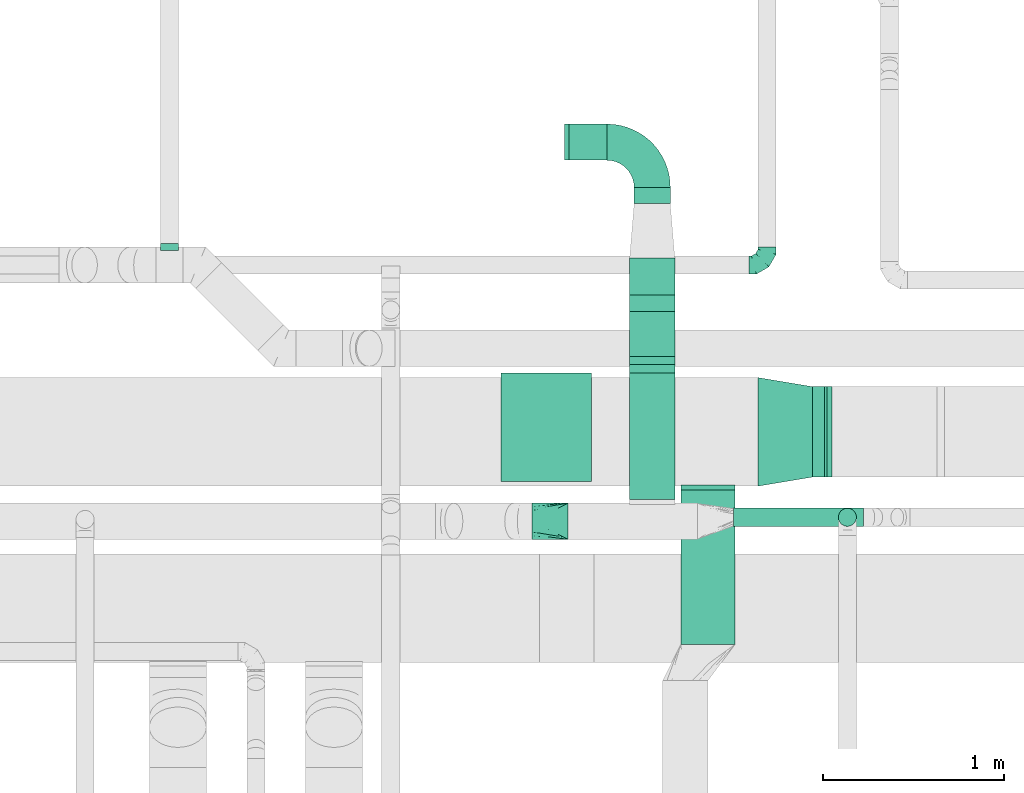
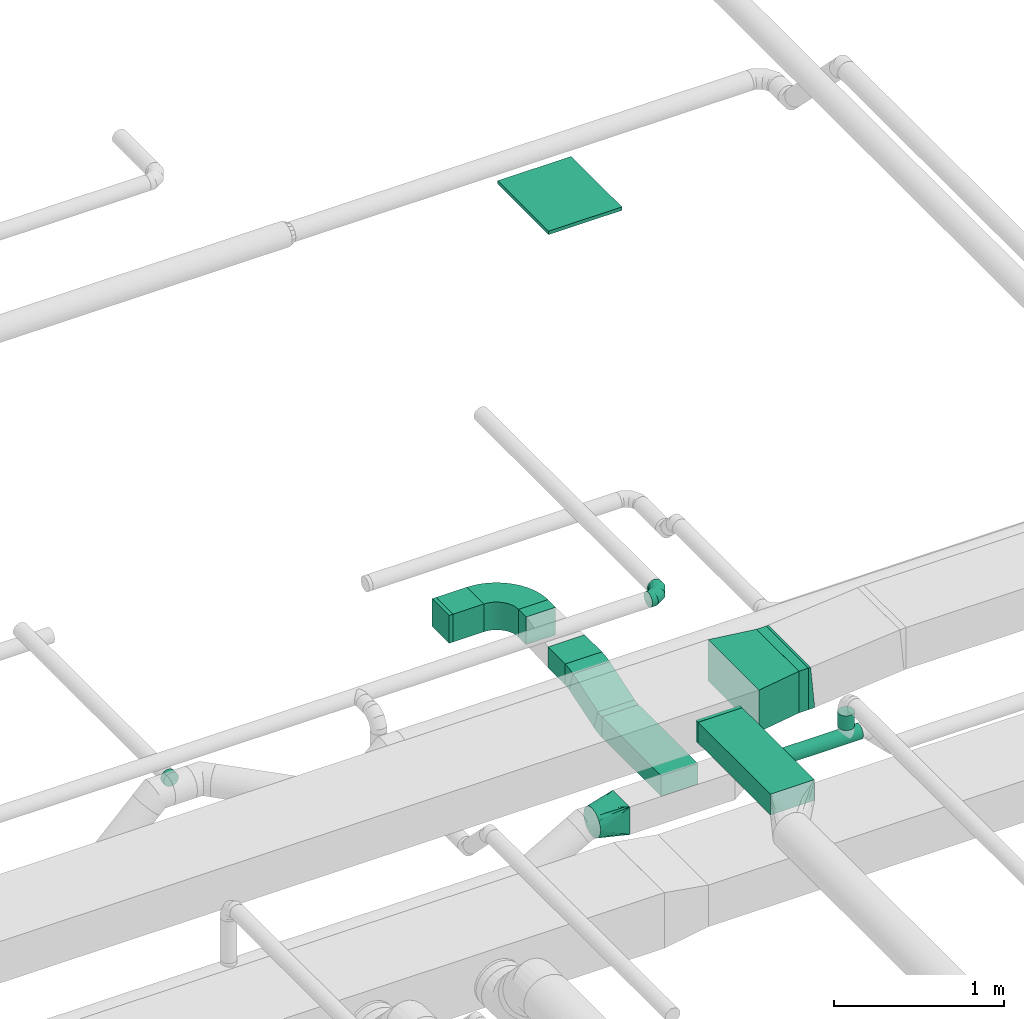
# One storey, part 43 of 60: 11 flow fittings, 9 flow segments.
"""IFC2X3 building model written with IfcOpenShell, lengths in millimetres."""

from ifc_helpers import new_model, entity, si_unit, converted_unit, derived_unit, direction, frame, frame_2d, origin, origin_2d_with_axis, place, context, subcontext, project, spatial, polyline, circle_curve, parameter, trimmed, segment, composite_curve, rectangle, circle, outline, extrude, faceted_brep, source, transform, mapped, material, type_object, type_shapes, element, save


model = new_model("IFC2X3")

# Units and contexts
model_context = context("Model", 3, precision=0.01, world=origin(), true_north=direction((6.12303176911189e-17, 1.0)))
body_context = subcontext(model_context, "Body", "Model", "MODEL_VIEW")
ifc_project = project(units=[si_unit("LENGTHUNIT", "METRE", prefix="MILLI"), si_unit("AREAUNIT", "SQUARE_METRE"), si_unit("VOLUMEUNIT", "CUBIC_METRE"), converted_unit("PLANEANGLEUNIT", "DEGREE", entity("IfcRatioMeasure", 0.0174532925199433), si_unit("PLANEANGLEUNIT", "RADIAN"), dimensions=[0, 0, 0, 0, 0, 0, 0]), si_unit("MASSUNIT", "GRAM", prefix="KILO"), derived_unit("MASSDENSITYUNIT", [(si_unit("MASSUNIT", "GRAM", prefix="KILO"), 1), (si_unit("LENGTHUNIT", "METRE"), -3)]), derived_unit("MOMENTOFINERTIAUNIT", [(si_unit("LENGTHUNIT", "METRE"), 4)]), si_unit("TIMEUNIT", "SECOND"), si_unit("FREQUENCYUNIT", "HERTZ"), si_unit("THERMODYNAMICTEMPERATUREUNIT", "DEGREE_CELSIUS"), derived_unit("THERMALTRANSMITTANCEUNIT", [(si_unit("MASSUNIT", "GRAM", prefix="KILO"), 1), (si_unit("THERMODYNAMICTEMPERATUREUNIT", "KELVIN"), -1), (si_unit("TIMEUNIT", "SECOND"), -3)]), derived_unit("VOLUMETRICFLOWRATEUNIT", [(si_unit("LENGTHUNIT", "METRE"), 3), (si_unit("TIMEUNIT", "SECOND"), -1)]), derived_unit("MASSFLOWRATEUNIT", [(si_unit("MASSUNIT", "GRAM", prefix="KILO"), 1), (si_unit("TIMEUNIT", "SECOND"), -1)]), derived_unit("ROTATIONALFREQUENCYUNIT", [(si_unit("TIMEUNIT", "SECOND"), -1)]), si_unit("ELECTRICCURRENTUNIT", "AMPERE"), si_unit("ELECTRICVOLTAGEUNIT", "VOLT"), si_unit("POWERUNIT", "WATT"), si_unit("FORCEUNIT", "NEWTON", prefix="KILO"), si_unit("ILLUMINANCEUNIT", "LUX"), si_unit("LUMINOUSFLUXUNIT", "LUMEN"), si_unit("LUMINOUSINTENSITYUNIT", "CANDELA"), derived_unit("USERDEFINED", [(si_unit("MASSUNIT", "GRAM", prefix="KILO"), -1), (si_unit("LENGTHUNIT", "METRE"), -2), (si_unit("TIMEUNIT", "SECOND"), 3), (si_unit("LUMINOUSFLUXUNIT", "LUMEN"), 1)]), derived_unit("LINEARVELOCITYUNIT", [(si_unit("LENGTHUNIT", "METRE"), 1), (si_unit("TIMEUNIT", "SECOND"), -1)]), si_unit("PRESSUREUNIT", "PASCAL"), derived_unit("USERDEFINED", [(si_unit("LENGTHUNIT", "METRE"), -2), (si_unit("MASSUNIT", "GRAM", prefix="KILO"), 1), (si_unit("TIMEUNIT", "SECOND"), -2)]), derived_unit("LINEARFORCEUNIT", [(si_unit("MASSUNIT", "GRAM", prefix="KILO"), 1), (si_unit("LENGTHUNIT", "METRE"), 1), (si_unit("TIMEUNIT", "SECOND"), -2), (si_unit("LENGTHUNIT", "METRE"), -1)]), derived_unit("PLANARFORCEUNIT", [(si_unit("MASSUNIT", "GRAM", prefix="KILO"), 1), (si_unit("LENGTHUNIT", "METRE"), 1), (si_unit("TIMEUNIT", "SECOND"), -2), (si_unit("LENGTHUNIT", "METRE"), -2)])], contexts=[model_context])

# Site, building, storey
site_placement = place(None, origin())
site = spatial("IfcSite", under=ifc_project, at=site_placement, CompositionType="ELEMENT")
building_placement = place(site_placement, origin())
building = spatial("IfcBuilding", under=site, at=building_placement, CompositionType="ELEMENT")
storey_placement = place(building_placement, frame((0.0, 0.0, 19800.0)))
storey = spatial("IfcBuildingStorey", under=building, at=storey_placement, CompositionType="ELEMENT", Elevation=19800.0)

# Flow segments
duct_segment_type_1 = type_object("IfcDuctSegmentType", PredefinedType="NOTDEFINED")
flow_segment_1_placement = place(storey_placement, frame((60318.37, 8189.68, 3500.0)))
element("IfcFlowSegment", 1, at=flow_segment_1_placement, inside=storey, type_object=duct_segment_type_1, context=body_context, shape_type="SweptSolid", body=[
    extrude(rectangle(XDim=854.274506525887, YDim=300.000000000001, at=origin_2d_with_axis()), frame((150.0, 427.14, 0.0), z_axis=(0.0, 0.0, 1.0), x_axis=(0.0, 1.0, 0.0)), (0.0, 0.0, 1.0), 150.000000000001),
])
flow_segment_2_placement = place(storey_placement, frame((59700.56, 10865.01, 3340.0)))
element("IfcFlowSegment", 2, at=flow_segment_2_placement, inside=storey, type_object=duct_segment_type_1, context=body_context, shape_type="SweptSolid", body=[
    extrude(rectangle(XDim=209.9999999999, YDim=200.0, at=origin_2d_with_axis()), frame((105.0, 100.0, 0.0), z_axis=(0.0, 0.0, 1.0), x_axis=(-1.0, 0.0, 0.0)), (0.0, 0.0, 1.0), 199.999999999998),
])
flow_segment_3_placement = place(storey_placement, frame((61045.49, 9113.95, 3420.0)))
element("IfcFlowSegment", 3, at=flow_segment_3_placement, inside=storey, type_object=duct_segment_type_1, context=body_context, shape_type="SweptSolid", body=[
    extrude(rectangle(XDim=65.8804029899107, YDim=500.0, at=origin_2d_with_axis()), frame((32.94, 250.0, 0.0)), (0.0, 0.0, 1.0), 300.000000000001),
])
flow_segment_4_placement = place(storey_placement, frame((60035.56, 9735.39, 3262.28)))
element("IfcFlowSegment", 4, at=flow_segment_4_placement, inside=storey, type_object=duct_segment_type_1, context=body_context, shape_type="SweptSolid", body=[
    extrude(rectangle(XDim=149.999999999999, YDim=308.637382267004, at=frame_2d((0.0, 0.0), x_axis=(0.0, 1.0))), frame((0.0, 169.94, 119.02), z_axis=(1.0, 0.0, 0.0), x_axis=(0.0, 0.951056516295144, 0.309016994374977)), (0.0, 0.0, 1.0), 249.999999999995),
])
flow_segment_5_placement = place(storey_placement, frame((60035.56, 10121.63, 3365.0)))
element("IfcFlowSegment", 5, at=flow_segment_5_placement, inside=storey, type_object=duct_segment_type_1, context=body_context, shape_type="SweptSolid", body=[
    extrude(rectangle(XDim=203.375527732258, YDim=250.000000000004, at=origin_2d_with_axis()), frame((125.0, 101.69, 0.0), z_axis=(0.0, 0.0, 1.0), x_axis=(0.0, 1.0, 0.0)), (0.0, 0.0, 1.0), 150.000000000001),
])
flow_segment_6_placement = place(storey_placement, frame((60060.56, 10625.01, 3340.0)))
element("IfcFlowSegment", 6, at=flow_segment_6_placement, inside=storey, type_object=duct_segment_type_1, context=body_context, shape_type="SweptSolid", body=[
    extrude(rectangle(XDim=90.0000000000727, YDim=199.999999999998, at=origin_2d_with_axis()), frame((100.0, 45.0, 0.0), z_axis=(0.0, 0.0, 1.0), x_axis=(0.0, -1.0, 0.0)), (0.0, 0.0, 1.0), 199.999999999998),
])
flow_segment_7_placement = place(storey_placement, frame((60035.56, 8990.01, 3247.6)))
element("IfcFlowSegment", 7, at=flow_segment_7_placement, inside=storey, type_object=duct_segment_type_1, context=body_context, shape_type="SweptSolid", body=[
    extrude(rectangle(XDim=699.035231222013, YDim=250.000000000004, at=origin_2d_with_axis()), frame((125.0, 349.52, 0.0), z_axis=(0.0, 0.0, 1.0), x_axis=(0.0, -1.0, 0.0)), (0.0, 0.0, 1.0), 150.000000000001),
])
duct_segment_type_2 = type_object("IfcDuctSegmentType", PredefinedType="NOTDEFINED")
flow_segment_8_placement = place(storey_placement, frame((60610.56, 8840.3, 3273.4)))
element("IfcFlowSegment", 8, at=flow_segment_8_placement, inside=storey, type_object=duct_segment_type_2, context=body_context, shape_type="SweptSolid", body=[
    extrude(circle(Radius=50.0, at=origin_2d_with_axis()), frame((0.0, 51.6, 51.6), z_axis=(1.0, 0.0, 0.0), x_axis=(0.0, -1.0, 0.0)), (0.0, 0.0, 1.0), 717.215396144101),
])
flow_segment_9_placement = place(storey_placement, frame((61187.66, 8840.3, 3394.99)))
element("IfcFlowSegment", 9, at=flow_segment_9_placement, inside=storey, type_object=duct_segment_type_2, context=body_context, shape_type="SweptSolid", body=[
    extrude(circle(Radius=50.0, at=origin_2d_with_axis()), frame((51.6, 51.6, 0.01), z_axis=(0.0, 0.000103666826367405, 0.999999994626595), x_axis=(1.0, 0.0, 0.0)), (0.0, 0.0, 1.0), 104.989634246177),
])

# Flow fittings
ifc_material = material()
duct_fitting_type_1 = type_object("IfcDuctFittingType", PredefinedType="NOTDEFINED", material=ifc_material)
shared_shape_1 = source(origin(), body_context, "Body", "SweptSolid", [
    extrude(rectangle(XDim=24.9999999999999, YDim=600.0, at=origin_2d_with_axis()), frame((12.5, 0.0, -250.0)), (0.0, 0.0, 1.0), 500.0),
])
type_shapes(duct_fitting_type_1, [shared_shape_1])
flow_fitting_1_placement = place(storey_placement, frame((59575.64, 9388.57, 7506.46), z_axis=(1.0, 0.0, 0.0), x_axis=(0.0, 0.0, -1.0)))
element("IfcFlowFitting", 10, at=flow_fitting_1_placement, inside=storey, type_object=duct_fitting_type_1, material=ifc_material, context=body_context, shape_type="MappedRepresentation", body=[
    mapped(shared_shape_1, transform((0.0, 0.0, 0.0), scale=1.0)),
])
duct_fitting_type_2 = type_object("IfcDuctFittingType", PredefinedType="NOTDEFINED", material=ifc_material)
shared_shape_2 = source(origin(), body_context, "Body", "SweptSolid", [
    extrude(rectangle(XDim=26.0960000000436, YDim=200.0, at=origin_2d_with_axis()), frame((6.95, 0.0, -100.0)), (0.0, 0.0, 1.0), 200.0),
])
type_shapes(duct_fitting_type_2, [shared_shape_2])
flow_fitting_2_placement = place(storey_placement, frame((59680.56, 10965.01, 3440.0), z_axis=(0.0, -1.0, 0.0), x_axis=(1.0, 0.0, 0.0)))
element("IfcFlowFitting", 11, at=flow_fitting_2_placement, inside=storey, type_object=duct_fitting_type_2, material=ifc_material, context=body_context, shape_type="MappedRepresentation", body=[
    mapped(shared_shape_2, transform((0.0, 0.0, 0.0), scale=1.0)),
])
duct_fitting_type_3 = type_object("IfcDuctFittingType", PredefinedType="NOTDEFINED", material=ifc_material)
shared_shape_3 = source(origin(), body_context, "Body", "SweptSolid", [
    extrude(rectangle(XDim=26.0960000000005, YDim=300.0, at=origin_2d_with_axis()), frame((6.95, 0.0, -75.0)), (0.0, 0.0, 1.0), 150.0),
])
type_shapes(duct_fitting_type_3, [shared_shape_3])
flow_fitting_3_placement = place(storey_placement, frame((60468.37, 9063.95, 3575.0), z_axis=(0.0, 0.0, -1.0), x_axis=(0.0, -1.0, 0.0)))
element("IfcFlowFitting", 12, at=flow_fitting_3_placement, inside=storey, type_object=duct_fitting_type_3, material=ifc_material, context=body_context, shape_type="MappedRepresentation", body=[
    mapped(shared_shape_3, transform((0.0, 0.0, 0.0), scale=1.0)),
])
duct_fitting_type_4 = type_object("IfcDuctFittingType", PredefinedType="NOTDEFINED", material=ifc_material)
shared_shape_4 = source(origin(), body_context, "Body", "SweptSolid", [
    extrude(outline(polyline([(-197.28, -271.26), (106.86, -271.26), (189.06, 221.94), (-98.64, 320.58), (-197.28, -271.26)])), frame((150.0, 0.0, -150.0), z_axis=(0.0, 0.0, 1.0), x_axis=(0.986393923832144, 0.164398987305356, 0.0)), (0.0, 0.0, 1.0), 300.0),
])
type_shapes(duct_fitting_type_4, [shared_shape_4])
flow_fitting_4_placement = place(storey_placement, frame((60745.49, 9363.95, 3570.0)))
element("IfcFlowFitting", 13, at=flow_fitting_4_placement, inside=storey, type_object=duct_fitting_type_4, material=ifc_material, context=body_context, shape_type="MappedRepresentation", body=[
    mapped(shared_shape_4, transform((0.0, 0.0, 0.0), scale=1.0)),
])
duct_fitting_type_5 = type_object("IfcDuctFittingType", PredefinedType="NOTDEFINED", material=ifc_material)
shared_shape_5 = source(origin(), body_context, "Body", "Brep", [
    faceted_brep([(-100.0, 0.0, -50.0), (-100.0, -12.94, -48.3), (-100.0, -25.0, -43.3), (-100.0, -35.36, -35.36), (-100.0, -43.3, -25.0), (-100.0, -48.3, -12.94), (-100.0, -50.0, 0.0), (-100.0, -48.3, 12.94), (-100.0, -43.3, 25.0), (-100.0, -35.36, 35.36), (-100.0, -25.0, 43.3), (-100.0, -12.94, 48.3), (-100.0, 0.0, 50.0), (-100.0, 12.94, 48.3), (-100.0, 25.0, 43.3), (-100.0, 35.36, 35.36), (-100.0, 43.3, 25.0), (-100.0, 48.3, 12.94), (-100.0, 50.0, 0.0), (-100.0, 48.3, -12.94), (-100.0, 43.3, -25.0), (-100.0, 35.36, -35.36), (-100.0, 25.0, -43.3), (-100.0, 12.94, -48.3), (-76.67, 12.94, 48.3), (-79.9, 25.0, 43.3), (-73.21, 0.0, 50.0), (-82.68, 35.36, 35.36), (-86.15, 48.3, 12.94), (-86.6, 50.0, 0.0), (-84.81, 43.3, 25.0), (-84.81, 43.3, -25.0), (-82.68, 35.36, -35.36), (-86.15, 48.3, -12.94), (-76.67, 12.94, -48.3), (-73.21, 0.0, -50.0), (-79.9, 25.0, -43.3), (-69.74, -12.94, -48.3), (-66.51, -25.0, -43.3), (-63.73, -35.36, -35.36), (-61.6, -43.3, -25.0), (-60.26, -48.3, -12.94), (-59.81, -50.0, 0.0), (-60.26, -48.3, 12.94), (-61.6, -43.3, 25.0), (-63.73, -35.36, 35.36), (-66.51, -25.0, 43.3), (-69.74, -12.94, 48.3), (-36.27, 36.27, 48.3), (-45.1, 45.1, 43.3), (-26.79, 26.79, 50.0), (-52.68, 52.68, 35.36), (-58.49, 58.49, 25.0), (-62.15, 62.15, 12.94), (-63.4, 63.4, 0.0), (-62.15, 62.15, -12.94), (-58.49, 58.49, -25.0), (-52.68, 52.68, -35.36), (-36.27, 36.27, -48.3), (-26.79, 26.79, -50.0), (-45.1, 45.1, -43.3), (-17.32, 17.32, -48.3), (-8.49, 8.49, -43.3), (-0.91, 0.91, -35.36), (4.9, -4.9, -25.0), (8.56, -8.56, -12.94), (9.81, -9.81, 0.0), (8.56, -8.56, 12.94), (4.9, -4.9, 25.0), (-0.91, 0.91, 35.36), (-8.49, 8.49, 43.3), (-17.32, 17.32, 48.3), (-12.94, 76.67, 48.3), (-25.0, 79.9, 43.3), (0.0, 73.21, 50.0), (-35.36, 82.68, 35.36), (-43.3, 84.81, 25.0), (-48.3, 86.15, 12.94), (-50.0, 86.6, 0.0), (-48.3, 86.15, -12.94), (-43.3, 84.81, -25.0), (-35.36, 82.68, -35.36), (-12.94, 76.67, -48.3), (0.0, 73.21, -50.0), (-25.0, 79.9, -43.3), (12.94, 69.74, -48.3), (25.0, 66.51, -43.3), (35.36, 63.73, -35.36), (43.3, 61.6, -25.0), (48.3, 60.26, -12.94), (50.0, 59.81, 0.0), (48.3, 60.26, 12.94), (43.3, 61.6, 25.0), (35.36, 63.73, 35.36), (25.0, 66.51, 43.3), (12.94, 69.74, 48.3), (-12.94, 100.0, -48.3), (-25.0, 100.0, -43.3), (-35.36, 100.0, -35.36), (-43.3, 100.0, -25.0), (-48.3, 100.0, -12.94), (-50.0, 100.0, 0.0), (-48.3, 100.0, 12.94), (-43.3, 100.0, 25.0), (-35.36, 100.0, 35.36), (-25.0, 100.0, 43.3), (-12.94, 100.0, 48.3), (0.0, 100.0, 50.0), (12.94, 100.0, 48.3), (25.0, 100.0, 43.3), (35.36, 100.0, 35.36), (43.3, 100.0, 25.0), (48.3, 100.0, 12.94), (50.0, 100.0, 0.0), (48.3, 100.0, -12.94), (43.3, 100.0, -25.0), (35.36, 100.0, -35.36), (25.0, 100.0, -43.3), (12.94, 100.0, -48.3), (0.0, 100.0, -50.0)], [[[0, 1, 2, 3, 4, 5, 6, 7, 8, 9, 10, 11, 12, 13, 14, 15, 16, 17, 18, 19, 20, 21, 22, 23]], [[24, 25, 14, 13]], [[26, 24, 13, 12]], [[14, 25, 27, 15]], [[28, 29, 18, 17]], [[30, 28, 17, 16]], [[15, 27, 30, 16]], [[20, 31, 32, 21]], [[33, 31, 20, 19]], [[18, 29, 33, 19]], [[34, 35, 0, 23]], [[36, 34, 23, 22]], [[32, 36, 22, 21]], [[2, 1, 37, 38]], [[3, 2, 38, 39]], [[0, 35, 37, 1]], [[5, 4, 40, 41]], [[6, 5, 41, 42]], [[3, 39, 40, 4]], [[6, 42, 43, 7]], [[7, 43, 44, 8]], [[8, 44, 45, 9]], [[10, 46, 47, 11]], [[11, 47, 26, 12]], [[10, 9, 45, 46]], [[48, 49, 25, 24]], [[50, 48, 24, 26]], [[27, 25, 49, 51]], [[52, 53, 28, 30]], [[51, 52, 30, 27]], [[29, 28, 53, 54]], [[55, 56, 31, 33]], [[54, 55, 33, 29]], [[57, 32, 31, 56]], [[58, 59, 35, 34]], [[60, 58, 34, 36]], [[57, 60, 36, 32]], [[37, 35, 59, 61]], [[38, 37, 61, 62]], [[39, 38, 62, 63]], [[41, 40, 64, 65]], [[42, 41, 65, 66]], [[63, 64, 40, 39]], [[43, 42, 66, 67]], [[44, 43, 67, 68]], [[68, 69, 45, 44]], [[46, 45, 69, 70]], [[47, 46, 70, 71]], [[26, 47, 71, 50]], [[72, 73, 49, 48]], [[74, 72, 48, 50]], [[51, 49, 73, 75]], [[76, 77, 53, 52]], [[75, 76, 52, 51]], [[54, 53, 77, 78]], [[79, 80, 56, 55]], [[78, 79, 55, 54]], [[81, 57, 56, 80]], [[82, 83, 59, 58]], [[84, 82, 58, 60]], [[81, 84, 60, 57]], [[61, 59, 83, 85]], [[62, 61, 85, 86]], [[63, 62, 86, 87]], [[65, 64, 88, 89]], [[66, 65, 89, 90]], [[87, 88, 64, 63]], [[67, 66, 90, 91]], [[68, 67, 91, 92]], [[92, 93, 69, 68]], [[70, 69, 93, 94]], [[71, 70, 94, 95]], [[50, 71, 95, 74]], [[96, 97, 98, 99, 100, 101, 102, 103, 104, 105, 106, 107, 108, 109, 110, 111, 112, 113, 114, 115, 116, 117, 118, 119]], [[72, 74, 107, 106]], [[73, 72, 106, 105]], [[75, 73, 105, 104]], [[77, 76, 103, 102]], [[78, 77, 102, 101]], [[75, 104, 103, 76]], [[78, 101, 100, 79]], [[79, 100, 99, 80]], [[80, 99, 98, 81]], [[96, 119, 83, 82]], [[97, 96, 82, 84]], [[84, 81, 98, 97]], [[83, 119, 118, 85]], [[85, 118, 117, 86]], [[86, 117, 116, 87]], [[88, 115, 114, 89]], [[89, 114, 113, 90]], [[87, 116, 115, 88]], [[91, 90, 113, 112]], [[92, 91, 112, 111]], [[93, 92, 111, 110]], [[95, 94, 109, 108]], [[74, 95, 108, 107]], [[110, 109, 94, 93]]]),
])
type_shapes(duct_fitting_type_5, [shared_shape_5])
flow_fitting_5_placement = place(storey_placement, frame((60795.49, 10285.62, 3650.0)))
element("IfcFlowFitting", 14, at=flow_fitting_5_placement, inside=storey, type_object=duct_fitting_type_5, material=ifc_material, context=body_context, shape_type="MappedRepresentation", body=[
    mapped(shared_shape_5, transform((0.0, 0.0, 0.0), scale=1.0)),
])
duct_fitting_type_6 = type_object("IfcDuctFittingType", PredefinedType="NOTDEFINED", material=ifc_material)
shared_shape_6 = source(origin(), body_context, "Body", "Brep", [
    faceted_brep([(20.0, 12.94, -48.3), (20.0, 25.0, -43.3), (20.0, 35.36, -35.36), (20.0, 43.3, -25.0), (20.0, 48.3, -12.94), (20.0, 50.0, 0.0), (20.0, 48.3, 12.94), (20.0, 43.3, 25.0), (20.0, 35.36, 35.36), (20.0, 25.0, 43.3), (20.0, 12.94, 48.3), (20.0, 0.0, 50.0), (20.0, -12.94, 48.3), (20.0, -25.0, 43.3), (20.0, -35.36, 35.36), (20.0, -43.3, 25.0), (20.0, -48.3, 12.94), (20.0, -50.0, 0.0), (20.0, -48.3, -12.94), (20.0, -43.3, -25.0), (20.0, -35.36, -35.36), (20.0, -25.0, -43.3), (20.0, -12.94, -48.3), (20.0, 0.0, -50.0), (0.0, 0.0, 50.0), (0.0, 12.94, 48.3), (-19.49, 12.94, 48.3), (-19.49, 0.0, 50.0), (0.0, 25.0, 43.3), (-19.49, 25.0, 43.3), (0.0, 35.36, 35.36), (-19.49, 35.36, 35.36), (0.0, 43.3, 25.0), (0.0, 48.3, 12.94), (-19.49, 48.3, 12.94), (-19.49, 43.3, 25.0), (0.0, 50.0, 0.0), (-19.49, 50.0, 0.0), (0.0, 48.3, -12.94), (-19.49, 48.3, -12.94), (0.0, 43.3, -25.0), (-19.49, 43.3, -25.0), (0.0, 35.36, -35.36), (-19.49, 35.36, -35.36), (0.0, 25.0, -43.3), (0.0, 12.94, -48.3), (-19.49, 12.94, -48.3), (-19.49, 25.0, -43.3), (0.0, 0.0, -50.0), (-19.49, 0.0, -50.0), (0.0, -12.94, -48.3), (-19.49, -12.94, -48.3), (0.0, -25.0, -43.3), (-19.49, -25.0, -43.3), (0.0, -35.36, -35.36), (-19.49, -35.36, -35.36), (0.0, -43.3, -25.0), (0.0, -48.3, -12.94), (-19.49, -48.3, -12.94), (-19.49, -43.3, -25.0), (0.0, -50.0, 0.0), (-19.49, -50.0, 0.0), (0.0, -48.3, 12.94), (-19.49, -48.3, 12.94), (0.0, -43.3, 25.0), (-19.49, -43.3, 25.0), (0.0, -35.36, 35.36), (-19.49, -35.36, 35.36), (0.0, -25.0, 43.3), (0.0, -12.94, 48.3), (-19.49, -12.94, 48.3), (-19.49, -25.0, 43.3)], [[[0, 1, 2, 3, 4, 5, 6, 7, 8, 9, 10, 11, 12, 13, 14, 15, 16, 17, 18, 19, 20, 21, 22, 23]], [[24, 11, 10, 25, 26, 27]], [[25, 10, 9, 28, 29, 26]], [[28, 9, 8, 30, 31, 29]], [[32, 7, 6, 33, 34, 35]], [[33, 6, 5, 36, 37, 34]], [[30, 8, 7, 32, 35, 31]], [[36, 5, 4, 38, 39, 37]], [[38, 4, 3, 40, 41, 39]], [[40, 3, 2, 42, 43, 41]], [[44, 1, 0, 45, 46, 47]], [[45, 0, 23, 48, 49, 46]], [[42, 2, 1, 44, 47, 43]], [[48, 23, 22, 50, 51, 49]], [[50, 22, 21, 52, 53, 51]], [[52, 21, 20, 54, 55, 53]], [[56, 19, 18, 57, 58, 59]], [[57, 18, 17, 60, 61, 58]], [[54, 20, 19, 56, 59, 55]], [[60, 17, 16, 62, 63, 61]], [[62, 16, 15, 64, 65, 63]], [[64, 15, 14, 66, 67, 65]], [[68, 13, 12, 69, 70, 71]], [[69, 12, 11, 24, 27, 70]], [[66, 14, 13, 68, 71, 67]], [[49, 51, 53, 55, 59, 58, 61, 63, 65, 67, 71, 70, 27, 26, 29, 31, 35, 34, 37, 39, 41, 43, 47, 46]]]),
])
type_shapes(duct_fitting_type_6, [shared_shape_6])
flow_fitting_6_placement = place(storey_placement, frame((57493.55, 10385.62, 3426.16), z_axis=(0.0, 0.0, -1.0), x_axis=(0.0, 1.0, 0.0)))
element("IfcFlowFitting", 15, at=flow_fitting_6_placement, inside=storey, type_object=duct_fitting_type_6, material=ifc_material, context=body_context, shape_type="MappedRepresentation", body=[
    mapped(shared_shape_6, transform((0.0, 0.0, 0.0), scale=1.0)),
])
duct_fitting_type_7 = type_object("IfcDuctFittingType", PredefinedType="NOTDEFINED", material=ifc_material)
shared_shape_7 = source(origin(), body_context, "Body", "Brep", [
    faceted_brep([(200.0, 30.9, 95.11), (200.0, 19.08, 96.98), (200.0, 9.54, 98.49), (200.0, 4.77, 99.24), (200.0, 0.0, 100.0), (200.0, -4.77, 99.24), (200.0, -9.54, 98.49), (200.0, -19.08, 96.98), (200.0, -30.9, 95.11), (200.0, -44.84, 88.0), (200.0, -58.78, 80.9), (200.0, -69.84, 69.84), (200.0, -80.9, 58.78), (200.0, -88.0, 44.84), (200.0, -95.11, 30.9), (200.0, -96.98, 19.08), (200.0, -98.49, 9.54), (200.0, -99.24, 4.77), (200.0, -100.0, 0.0), (200.0, -99.24, -4.77), (200.0, -98.49, -9.54), (200.0, -96.98, -19.08), (200.0, -95.11, -30.9), (200.0, -88.0, -44.84), (200.0, -80.9, -58.78), (200.0, -69.84, -69.84), (200.0, -58.78, -80.9), (200.0, -44.84, -88.0), (200.0, -30.9, -95.11), (200.0, -19.08, -96.98), (200.0, -9.54, -98.49), (200.0, -4.77, -99.24), (200.0, 0.0, -100.0), (200.0, 4.77, -99.24), (200.0, 9.54, -98.49), (200.0, 19.08, -96.98), (200.0, 30.9, -95.11), (200.0, 44.84, -88.0), (200.0, 58.78, -80.9), (200.0, 69.84, -69.84), (200.0, 80.9, -58.78), (200.0, 88.0, -44.84), (200.0, 95.11, -30.9), (200.0, 96.98, -19.08), (200.0, 98.49, -9.54), (200.0, 99.24, -4.77), (200.0, 100.0, 0.0), (200.0, 99.24, 4.77), (200.0, 98.49, 9.54), (200.0, 96.98, 19.08), (200.0, 95.11, 30.9), (200.0, 88.0, 44.84), (200.0, 80.9, 58.78), (200.0, 69.84, 69.84), (200.0, 58.78, 80.9), (200.0, 44.84, 88.0), (0.0, -100.0, 100.0), (0.0, 100.0, 100.0), (0.0, 100.0, -100.0), (0.0, -100.0, -100.0), (104.11, -47.94, 100.0), (100.0, -83.15, 87.43), (26.03, -86.99, 100.0), (78.09, -60.96, 100.0), (52.06, -73.97, 100.0), (188.01, -5.99, 100.0), (176.03, -11.99, 100.0), (152.06, -23.97, 100.0), (128.09, -35.96, 100.0), (52.06, -100.0, 73.97), (78.09, -100.0, 60.96), (104.11, -100.0, 47.94), (128.09, -100.0, 35.96), (152.06, -100.0, 23.97), (176.03, -100.0, 11.99), (188.01, -100.0, 5.99), (26.03, -100.0, 86.99), (26.03, -100.0, -86.99), (52.06, -100.0, -73.97), (78.09, -100.0, -60.96), (104.11, -100.0, -47.94), (128.09, -100.0, -35.96), (152.06, -100.0, -23.97), (176.03, -100.0, -11.99), (188.01, -100.0, -5.99), (100.0, -87.43, -83.15), (52.06, -73.97, -100.0), (78.09, -60.96, -100.0), (104.11, -47.94, -100.0), (128.09, -35.96, -100.0), (152.06, -23.97, -100.0), (176.03, -11.99, -100.0), (188.01, -5.99, -100.0), (26.03, -86.99, -100.0), (26.03, 86.99, -100.0), (52.06, 73.97, -100.0), (78.09, 60.96, -100.0), (104.11, 47.94, -100.0), (128.09, 35.96, -100.0), (152.06, 23.97, -100.0), (176.03, 11.99, -100.0), (188.01, 5.99, -100.0), (100.0, 83.15, -87.43), (52.06, 100.0, -73.97), (78.09, 100.0, -60.96), (104.11, 100.0, -47.94), (128.09, 100.0, -35.96), (152.06, 100.0, -23.97), (176.03, 100.0, -11.99), (188.01, 100.0, -5.99), (26.03, 100.0, -86.99), (26.03, 100.0, 86.99), (52.06, 100.0, 73.97), (78.09, 100.0, 60.96), (104.11, 100.0, 47.94), (128.09, 100.0, 35.96), (152.06, 100.0, 23.97), (176.03, 100.0, 11.99), (188.01, 100.0, 5.99), (100.0, 87.43, 83.15), (52.06, 73.97, 100.0), (78.09, 60.96, 100.0), (104.11, 47.94, 100.0), (128.09, 35.96, 100.0), (152.06, 23.97, 100.0), (176.03, 11.99, 100.0), (188.01, 5.99, 100.0), (26.03, 86.99, 100.0)], [[[0, 1, 2, 3, 4, 5, 6, 7, 8, 9, 10, 11, 12, 13, 14, 15, 16, 17, 18, 19, 20, 21, 22, 23, 24, 25, 26, 27, 28, 29, 30, 31, 32, 33, 34, 35, 36, 37, 38, 39, 40, 41, 42, 43, 44, 45, 46, 47, 48, 49, 50, 51, 52, 53, 54, 55]], [[56, 57, 58, 59]], [[60, 9, 8]], [[56, 61, 62]], [[9, 60, 63, 64]], [[65, 66, 67, 68, 60, 8, 7, 6, 5, 4]], [[62, 61, 10]], [[13, 69, 70, 71]], [[64, 10, 9]], [[14, 71, 72, 73, 74, 75, 18, 17, 16, 15]], [[12, 76, 69]], [[71, 14, 13]], [[61, 76, 11]], [[10, 64, 62]], [[76, 12, 11]], [[10, 61, 11]], [[61, 56, 76]], [[69, 13, 12]], [[75, 74, 73, 72, 71, 70, 69, 76, 56, 59, 77, 78, 79, 80, 81, 82, 83, 84, 18]], [[80, 23, 22]], [[59, 85, 77]], [[23, 80, 79, 78]], [[84, 83, 82, 81, 80, 22, 21, 20, 19, 18]], [[77, 85, 24]], [[27, 86, 87, 88]], [[78, 24, 23]], [[28, 88, 89, 90, 91, 92, 32, 31, 30, 29]], [[26, 93, 86]], [[88, 28, 27]], [[85, 93, 25]], [[24, 78, 77]], [[93, 26, 25]], [[24, 85, 25]], [[85, 59, 93]], [[86, 27, 26]], [[92, 91, 90, 89, 88, 87, 86, 93, 59, 58, 94, 95, 96, 97, 98, 99, 100, 101, 32]], [[97, 37, 36]], [[58, 102, 94]], [[37, 97, 96, 95]], [[101, 100, 99, 98, 97, 36, 35, 34, 33, 32]], [[94, 102, 38]], [[41, 103, 104, 105]], [[95, 38, 37]], [[42, 105, 106, 107, 108, 109, 46, 45, 44, 43]], [[40, 110, 103]], [[105, 42, 41]], [[102, 110, 39]], [[38, 95, 94]], [[110, 40, 39]], [[38, 102, 39]], [[102, 58, 110]], [[103, 41, 40]], [[58, 57, 111, 112, 113, 114, 115, 116, 117, 118, 46, 109, 108, 107, 106, 105, 104, 103, 110]], [[114, 51, 50]], [[57, 119, 111]], [[51, 114, 113, 112]], [[118, 117, 116, 115, 114, 50, 49, 48, 47, 46]], [[111, 119, 52]], [[55, 120, 121, 122]], [[112, 52, 51]], [[0, 122, 123, 124, 125, 126, 4, 3, 2, 1]], [[54, 127, 120]], [[122, 0, 55]], [[119, 127, 53]], [[52, 112, 111]], [[127, 54, 53]], [[52, 119, 53]], [[119, 57, 127]], [[120, 55, 54]], [[57, 56, 62, 64, 63, 60, 68, 67, 66, 65, 4, 126, 125, 124, 123, 122, 121, 120, 127]]]),
])
type_shapes(duct_fitting_type_7, [shared_shape_7])
flow_fitting_7_placement = place(storey_placement, frame((59695.58, 8870.01, 3325.0), z_axis=(0.0, 0.0, 1.0), x_axis=(-1.0, 0.0, 0.0)))
element("IfcFlowFitting", 16, at=flow_fitting_7_placement, inside=storey, type_object=duct_fitting_type_7, material=ifc_material, context=body_context, shape_type="MappedRepresentation", body=[
    mapped(shared_shape_7, transform((0.0, 0.0, 0.0), scale=1.0)),
])
duct_fitting_type_8 = type_object("IfcDuctFittingType", PredefinedType="NOTDEFINED", material=ifc_material)
shared_shape_8 = source(origin(), body_context, "Body", "SweptSolid", [
    extrude(outline(composite_curve([segment(polyline([(-225.0, -125.0), (-25.0, -125.0)]), True, "CONTINUOUS"), segment(trimmed(circle_curve(frame_2d((125.0, -125.0), x_axis=(0.0, 1.0)), 150.0), [parameter(0.0)], [parameter(90.0)], True, "PARAMETER"), False, "CONTINUOUS"), segment(polyline([(125.0, 25.0), (125.0, 225.0)]), True, "CONTINUOUS"), segment(trimmed(circle_curve(frame_2d((125.0, -125.0), x_axis=(0.0, 1.0)), 350.0), [parameter(0.0)], [parameter(90.0)], True, "PARAMETER"), True, "CONTINUOUS")], self_intersect=False)), frame((-125.0, 125.0, -100.0), z_axis=(0.0, 0.0, 1.0), x_axis=(-1.0, 0.0, 0.0)), (0.0, 0.0, 1.0), 200.0),
])
type_shapes(duct_fitting_type_8, [shared_shape_8])
flow_fitting_8_placement = place(storey_placement, frame((60160.56, 10965.01, 3440.0), z_axis=(0.0, 0.0, 1.0), x_axis=(0.0, 1.0, 0.0)))
element("IfcFlowFitting", 17, at=flow_fitting_8_placement, inside=storey, type_object=duct_fitting_type_8, material=ifc_material, context=body_context, shape_type="MappedRepresentation", body=[
    mapped(shared_shape_8, transform((0.0, 0.0, 0.0), scale=1.0)),
])
duct_fitting_type_9 = type_object("IfcDuctFittingType", PredefinedType="NOTDEFINED", material=ifc_material)
shared_shape_9 = source(origin(), body_context, "Body", "SweptSolid", [
    extrude(outline(composite_curve([segment(polyline([(-150.66, -14.09), (149.34, -14.09)]), True, "CONTINUOUS"), segment(trimmed(circle_curve(frame_2d((299.34, -14.09), x_axis=(-0.99557950271408, 0.093922594595683)), 150.0), [parameter(0.0)], [parameter(5.38931175997428)], True, "PARAMETER"), False, "CONTINUOUS"), segment(polyline([(150.0, 0.0), (-148.67, 28.18)]), True, "CONTINUOUS"), segment(trimmed(circle_curve(frame_2d((299.34, -14.09), x_axis=(-0.99557950271408, 0.093922594595683)), 450.0), [parameter(0.0)], [parameter(5.38931175997428)], True, "PARAMETER"), True, "CONTINUOUS")], self_intersect=False)), frame((-0.03, 0.66, -250.0), z_axis=(0.0, 0.0, 1.0), x_axis=(-0.0939225945956836, 0.99557950271408, 0.0)), (0.0, 0.0, 1.0), 500.0),
])
type_shapes(duct_fitting_type_9, [shared_shape_9])
flow_fitting_9_placement = place(storey_placement, frame((61125.49, 9363.95, 3570.0), z_axis=(0.0, -1.0, 0.0), x_axis=(1.0, 0.0, 0.0)))
element("IfcFlowFitting", 18, at=flow_fitting_9_placement, inside=storey, type_object=duct_fitting_type_9, material=ifc_material, context=body_context, shape_type="MappedRepresentation", body=[
    mapped(shared_shape_9, transform((0.0, 0.0, 0.0), scale=1.0)),
])
duct_fitting_type_10 = type_object("IfcDuctFittingType", PredefinedType="NOTDEFINED", material=ifc_material)
shared_shape_10 = source(origin(), body_context, "Body", "SweptSolid", [
    extrude(outline(composite_curve([segment(polyline([(-80.51, -34.76), (69.49, -34.76)]), True, "CONTINUOUS"), segment(trimmed(circle_curve(frame_2d((219.49, -34.76), x_axis=(-0.951056516295154, 0.309016994374947)), 150.0), [parameter(0.0)], [parameter(18.0)], True, "PARAMETER"), False, "CONTINUOUS"), segment(polyline([(76.84, 11.59), (-65.82, 57.94)]), True, "CONTINUOUS"), segment(trimmed(circle_curve(frame_2d((219.49, -34.76), x_axis=(-0.951056516295154, 0.309016994374947)), 300.0), [parameter(0.0)], [parameter(18.0)], True, "PARAMETER"), True, "CONTINUOUS")], self_intersect=False)), frame((-0.87, 5.51, -125.0), z_axis=(0.0, 0.0, 1.0), x_axis=(-0.309016994374947, 0.951056516295154, 0.0)), (0.0, 0.0, 1.0), 250.0),
])
type_shapes(duct_fitting_type_10, [shared_shape_10])
for number, where, z_axis, x_axis in (
    (19, (60160.56, 10085.99, 3440.0), (-1.0, 0.0, 0.0), (0.0, 0.951056516295141, 0.309016994374985)),
    (20, (60160.56, 9724.68, 3322.6), (-1.0, 0.0, 0.0), (0.0, -0.951056516295143, -0.30901699437498)),
):
    element("IfcFlowFitting", number, at=place(storey_placement, frame(where, z_axis=z_axis, x_axis=x_axis)), inside=storey, type_object=duct_fitting_type_10, material=ifc_material, context=body_context, shape_type="MappedRepresentation", body=[
        mapped(shared_shape_10, transform((0.0, 0.0, 0.0), scale=1.0)),
    ])

save(model, "model.ifc")
